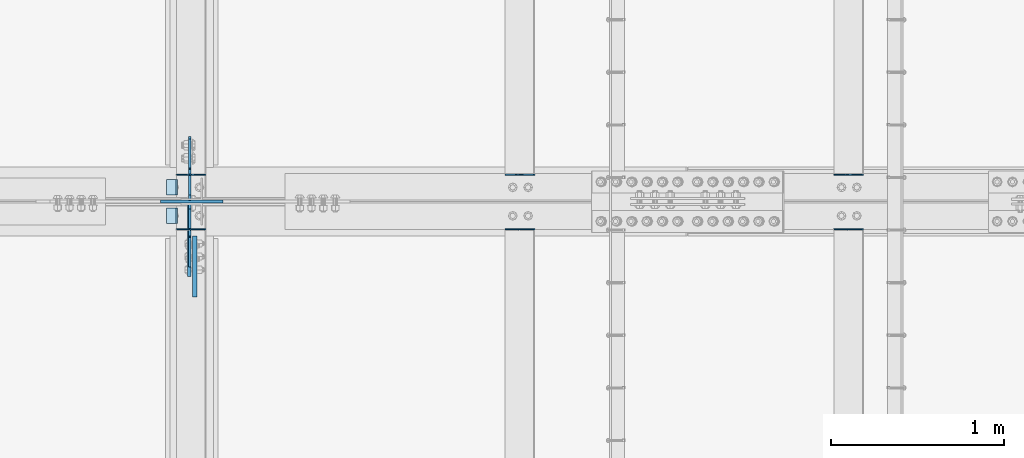
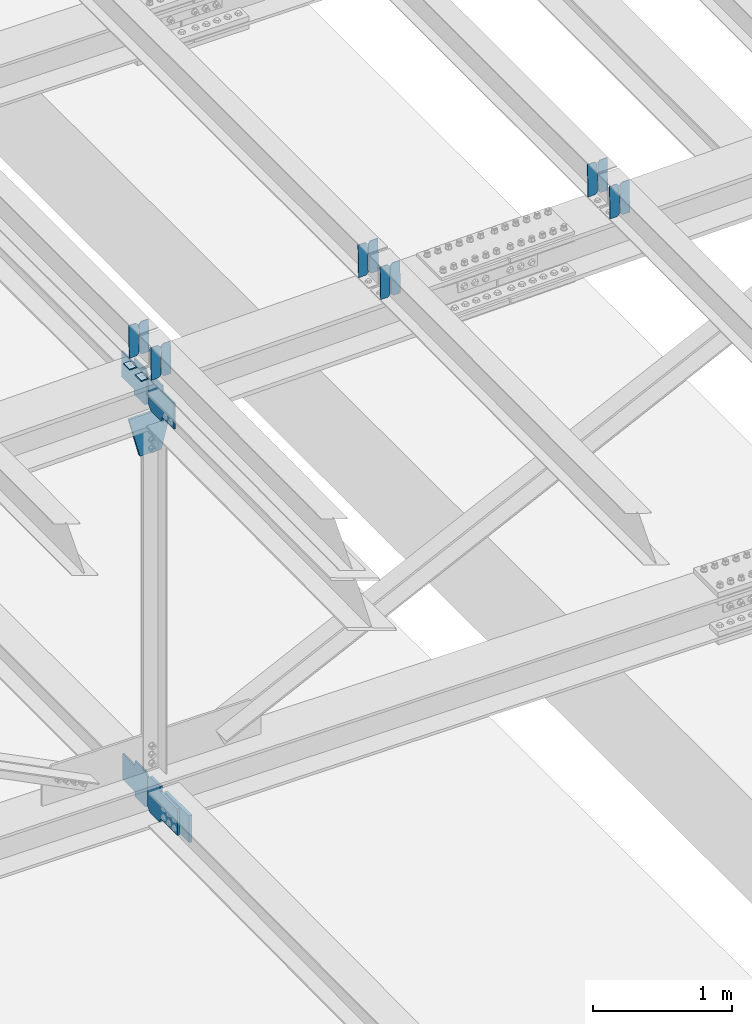
# One storey, part 3300 of 3843: 20 plates, 9 elements without a shape of their own.
"""IFC2X3 building model written with IfcOpenShell, lengths in millimetres."""

from ifc_helpers import new_model, si_unit, frame, origin_with_axes, place, context, subcontext, project, spatial, faceted_brep, material, type_object, element, aggregate, save


model = new_model("IFC2X3")

# Units and contexts
model_context = context("Model", 3, precision=1e-05, world=origin_with_axes())
body_context = subcontext(model_context, "Body", "Model", "MODEL_VIEW")
ifc_project = project(units=[si_unit("LENGTHUNIT", "METRE", prefix="MILLI"), si_unit("AREAUNIT", "SQUARE_METRE"), si_unit("VOLUMEUNIT", "CUBIC_METRE"), si_unit("MASSUNIT", "GRAM", prefix="KILO"), si_unit("TIMEUNIT", "SECOND"), si_unit("PLANEANGLEUNIT", "RADIAN"), si_unit("SOLIDANGLEUNIT", "STERADIAN"), si_unit("THERMODYNAMICTEMPERATUREUNIT", "DEGREE_CELSIUS"), si_unit("LUMINOUSINTENSITYUNIT", "LUMEN")], contexts=[model_context])

# Site, building, storey
site_placement = place(None, origin_with_axes())
site = spatial("IfcSite", under=ifc_project, at=site_placement, CompositionType="ELEMENT")
building_placement = place(site_placement, origin_with_axes())
building = spatial("IfcBuilding", under=site, at=building_placement, Name="Undefined", CompositionType="ELEMENT")
storey_placement = place(building_placement, origin_with_axes())
storey = spatial("IfcBuildingStorey", under=building, at=storey_placement, Name="Undefined", CompositionType="ELEMENT", Elevation=0.0)

# Assembly, plates
assembly_1_placement = place(storey_placement, origin_with_axes())
assembly_1 = element("IfcElementAssembly", 1, at=assembly_1_placement, inside=storey, Name="BEAM", AssemblyPlace="NOTDEFINED", PredefinedType="RIGID_FRAME")
ifc_material = material(Name="STEEL/A572-50")
plate_type_1 = type_object("IfcPlateType", PredefinedType="NOTDEFINED")
plate_1_placement = place(assembly_1_placement, frame((62718.6964784431, 42358.2339364471, 46061.7205786857), z_axis=(-0.0211520982314614, -0.0018756519998351, 0.999774509912101), x_axis=(-0.999776269352655, 3.88860000353947e-05, -0.0211520620074247)))
plate_1 = element("IfcPlate", 2, at=plate_1_placement, type_object=plate_type_1, material=ifc_material, Name="PLATE", context=body_context, shape_type="Brep", body=[
    faceted_brep([(0.0, -3.17499999999927, 0.0), (6.83940015733242e-10, -3.17499999996653, 288.924999998613), (6.54836185276508e-10, 3.17500000001746, 288.924999998591), (0.0, 3.17499999999927, 0.0), (60.3250007643655, -3.17500000017753, 288.924999998606), (60.3250007643219, 3.17499999979918, 288.924999998584), (79.3750000013097, -3.17500000025029, 269.875000761494), (79.375000001266, 3.17499999972642, 269.875000761487), (79.375000000713, -3.17500000026484, 19.0499992370605), (79.3750000006985, 3.17499999971187, 19.0499992370533), (60.325000763667, -3.17500000020664, -1.45519152283669e-11), (60.3250007636234, 3.17499999977736, -3.63797880709171e-11)], [[[0, 1, 2, 3]], [[1, 4, 5, 2]], [[4, 6, 7, 5]], [[6, 8, 9, 7]], [[8, 10, 11, 9]], [[10, 0, 3, 11]], [[5, 7, 9, 11, 3, 2]], [[10, 8, 6, 4, 1, 0]]]),
])
plate_2_placement = place(assembly_1_placement, frame((62632.9906577534, 42358.2373382604, 46059.9073182755), z_axis=(-0.0211520982314614, -0.0018756519998351, 0.999774509912101), x_axis=(-0.999776269352655, 3.88860000353947e-05, -0.0211520620074247)))
plate_2 = element("IfcPlate", 3, at=plate_2_placement, type_object=plate_type_1, material=ifc_material, Name="PLATE", context=body_context, shape_type="Brep", body=[
    faceted_brep([(4.36557456851006e-11, -3.17499999998836, 19.0499992370969), (6.11180439591408e-10, -3.17499999996653, 269.875000761516), (5.96628524363041e-10, 3.17500000001746, 269.875000761502), (1.45519152283669e-11, 3.17499999998836, 19.0499992370824), (19.0499992376572, -3.17500000003201, 288.924999998606), (19.0499992376281, 3.1749999999447, 288.924999998584), (79.3750000013242, -3.17500000025029, 288.924999998591), (79.3750000013097, 3.1749999997337, 288.92499999857), (79.3750000006548, -3.17500000026484, -2.18278728425503e-11), (79.3750000006403, 3.17499999969732, -2.91038304567337e-11), (19.0499992370023, -3.17500000005384, 0.0), (19.0499992369587, 3.17499999992287, -1.45519152283669e-11)], [[[0, 1, 2, 3]], [[1, 4, 5, 2]], [[4, 6, 7, 5]], [[6, 8, 9, 7]], [[8, 10, 11, 9]], [[10, 0, 3, 11]], [[5, 7, 9, 11, 3, 2]], [[10, 8, 6, 4, 1, 0]]]),
])

assembly_2_placement = place(storey_placement, origin_with_axes())
assembly_2 = element("IfcElementAssembly", 4, at=assembly_2_placement, inside=storey, Name="BEAM", AssemblyPlace="NOTDEFINED", PredefinedType="RIGID_FRAME")
plate_3_placement = place(assembly_2_placement, frame((62718.6964783463, 42042.5498323531, 46060.1628185439), z_axis=(-0.0211520980428759, -0.0079279149992217, 0.999744835901716), x_axis=(-0.99977626934649, 0.000167730000095165, -0.0211514330073057)))
plate_3 = element("IfcPlate", 5, at=plate_3_placement, type_object=plate_type_1, material=ifc_material, Name="PLATE", context=body_context, shape_type="Brep", body=[
    faceted_brep([(0.0, -3.17499999999927, 0.0), (6.83940015733242e-10, -3.17499999996653, 288.924999998613), (6.54836185276508e-10, 3.17500000001746, 288.924999998591), (0.0, 3.17499999999927, 0.0), (60.3250007643655, -3.17500000017753, 288.924999998606), (60.3250007643219, 3.17499999979918, 288.924999998584), (79.3750000013097, -3.17500000025029, 269.875000761494), (79.375000001266, 3.17499999972642, 269.875000761487), (79.375000000713, -3.17500000026484, 19.0499992370605), (79.3750000006985, 3.17499999971187, 19.0499992370533), (60.325000763667, -3.17500000020664, -1.45519152283669e-11), (60.3250007636234, 3.17499999977736, -3.63797880709171e-11)], [[[0, 1, 2, 3]], [[1, 4, 5, 2]], [[4, 6, 7, 5]], [[6, 8, 9, 7]], [[8, 10, 11, 9]], [[10, 0, 3, 11]], [[5, 7, 9, 11, 3, 2]], [[10, 8, 6, 4, 1, 0]]]),
])
plate_4_placement = place(assembly_2_placement, frame((62632.9906576567, 42042.5642109695, 46058.3496119529), z_axis=(-0.0211520980428759, -0.0079279149992217, 0.999744835901716), x_axis=(-0.99977626934649, 0.000167730000095165, -0.0211514330073057)))
plate_4 = element("IfcPlate", 6, at=plate_4_placement, type_object=plate_type_1, material=ifc_material, Name="PLATE", context=body_context, shape_type="Brep", body=[
    faceted_brep([(4.36557456851006e-11, -3.17499999998836, 19.0499992370969), (6.11180439591408e-10, -3.17499999996653, 269.875000761516), (5.96628524363041e-10, 3.17500000001746, 269.875000761502), (1.45519152283669e-11, 3.17499999998836, 19.0499992370824), (19.0499992376572, -3.17500000003201, 288.924999998606), (19.0499992376281, 3.1749999999447, 288.924999998584), (79.3750000013242, -3.17500000025029, 288.924999998591), (79.3750000013097, 3.1749999997337, 288.92499999857), (79.3750000006548, -3.17500000026484, -2.18278728425503e-11), (79.3750000006403, 3.17499999969732, -2.91038304567337e-11), (19.0499992370023, -3.17500000005384, 0.0), (19.0499992369587, 3.17499999992287, -1.45519152283669e-11)], [[[0, 1, 2, 3]], [[1, 4, 5, 2]], [[4, 6, 7, 5]], [[6, 8, 9, 7]], [[8, 10, 11, 9]], [[10, 0, 3, 11]], [[5, 7, 9, 11, 3, 2]], [[10, 8, 6, 4, 1, 0]]]),
])

assembly_3_placement = place(storey_placement, origin_with_axes())
assembly_3 = element("IfcElementAssembly", 7, at=assembly_3_placement, inside=storey, Name="BEAM", AssemblyPlace="NOTDEFINED", PredefinedType="RIGID_FRAME")
plate_5_placement = place(assembly_3_placement, frame((66528.6964782898, 42358.2722356688, 46144.1590912377), z_axis=(-0.0211520975136227, -0.00200431100054993, 0.999774260274882), x_axis=(-0.999776269341419, 4.27870000128944e-05, -0.0211520550071887)))
plate_5 = element("IfcPlate", 8, at=plate_5_placement, type_object=plate_type_1, material=ifc_material, Name="PLATE", context=body_context, shape_type="Brep", body=[
    faceted_brep([(0.0, -3.17499999999927, 0.0), (6.83940015733242e-10, -3.17499999996653, 288.924999998613), (6.54836185276508e-10, 3.17500000001746, 288.924999998591), (0.0, 3.17499999999927, 0.0), (60.3250007643655, -3.17500000017753, 288.924999998606), (60.3250007643219, 3.17499999979918, 288.924999998584), (79.3750000013097, -3.17500000025029, 269.875000761494), (79.375000001266, 3.17499999972642, 269.875000761487), (79.375000000713, -3.17500000026484, 19.0499992370605), (79.3750000006985, 3.17499999971187, 19.0499992370533), (60.325000763667, -3.17500000020664, -1.45519152283669e-11), (60.3250007636234, 3.17499999977736, -3.63797880709171e-11)], [[[0, 1, 2, 3]], [[1, 4, 5, 2]], [[4, 6, 7, 5]], [[6, 8, 9, 7]], [[8, 10, 11, 9]], [[10, 0, 3, 11]], [[5, 7, 9, 11, 3, 2]], [[10, 8, 6, 4, 1, 0]]]),
])
plate_6_placement = place(assembly_3_placement, frame((66442.9906575995, 42358.275870825, 46142.3458312798), z_axis=(-0.0211520975136227, -0.00200431100054993, 0.999774260274882), x_axis=(-0.999776269341419, 4.27870000128944e-05, -0.0211520550071887)))
plate_6 = element("IfcPlate", 9, at=plate_6_placement, type_object=plate_type_1, material=ifc_material, Name="PLATE", context=body_context, shape_type="Brep", body=[
    faceted_brep([(4.36557456851006e-11, -3.17499999998836, 19.0499992370969), (6.11180439591408e-10, -3.17499999996653, 269.875000761516), (5.96628524363041e-10, 3.17500000001746, 269.875000761502), (1.45519152283669e-11, 3.17499999998836, 19.0499992370824), (19.0499992376572, -3.17500000003201, 288.924999998606), (19.0499992376281, 3.1749999999447, 288.924999998584), (79.3750000013242, -3.17500000025029, 288.924999998591), (79.3750000013097, 3.1749999997337, 288.92499999857), (79.3750000006548, -3.17500000026484, -2.18278728425503e-11), (79.3750000006403, 3.17499999969732, -2.91038304567337e-11), (19.0499992370023, -3.17500000005384, 0.0), (19.0499992369587, 3.17499999992287, -1.45519152283669e-11)], [[[0, 1, 2, 3]], [[1, 4, 5, 2]], [[4, 6, 7, 5]], [[6, 8, 9, 7]], [[8, 10, 11, 9]], [[10, 0, 3, 11]], [[5, 7, 9, 11, 3, 2]], [[10, 8, 6, 4, 1, 0]]]),
])
aggregate(assembly_3, [plate_5, plate_6])

assembly_4_placement = place(storey_placement, origin_with_axes())
assembly_4 = element("IfcElementAssembly", 10, at=assembly_4_placement, inside=storey, Name="BEAM", AssemblyPlace="NOTDEFINED", PredefinedType="RIGID_FRAME")
plate_7_placement = place(assembly_4_placement, frame((66528.6964782749, 42042.5488447947, 46142.5816774789), z_axis=(-0.0211520974882006, -0.00792463099960153, 0.999744861949973), x_axis=(-0.99977626934649, 0.000167730000095165, -0.0211514330073057)))
plate_7 = element("IfcPlate", 11, at=plate_7_placement, type_object=plate_type_1, material=ifc_material, Name="PLATE", context=body_context, shape_type="Brep", body=[
    faceted_brep([(0.0, -3.17499999999927, 0.0), (6.83940015733242e-10, -3.17499999996653, 288.924999998613), (6.54836185276508e-10, 3.17500000001746, 288.924999998591), (0.0, 3.17499999999927, 0.0), (60.3250007643655, -3.17500000017753, 288.924999998606), (60.3250007643219, 3.17499999979918, 288.924999998584), (79.3750000013097, -3.17500000025029, 269.875000761494), (79.375000001266, 3.17499999972642, 269.875000761487), (79.375000000713, -3.17500000026484, 19.0499992370605), (79.3750000006985, 3.17499999971187, 19.0499992370533), (60.325000763667, -3.17500000020664, -1.45519152283669e-11), (60.3250007636234, 3.17499999977736, -3.63797880709171e-11)], [[[0, 1, 2, 3]], [[1, 4, 5, 2]], [[4, 6, 7, 5]], [[6, 8, 9, 7]], [[8, 10, 11, 9]], [[10, 0, 3, 11]], [[5, 7, 9, 11, 3, 2]], [[10, 8, 6, 4, 1, 0]]]),
])
plate_8_placement = place(assembly_4_placement, frame((66442.9906575837, 42042.5632174562, 46140.7684708411), z_axis=(-0.0211520974882006, -0.00792463099960153, 0.999744861949973), x_axis=(-0.99977626934649, 0.000167730000095165, -0.0211514330073057)))
plate_8 = element("IfcPlate", 12, at=plate_8_placement, type_object=plate_type_1, material=ifc_material, Name="PLATE", context=body_context, shape_type="Brep", body=[
    faceted_brep([(4.36557456851006e-11, -3.17499999998836, 19.0499992370969), (6.11180439591408e-10, -3.17499999996653, 269.875000761516), (5.96628524363041e-10, 3.17500000001746, 269.875000761502), (1.45519152283669e-11, 3.17499999998836, 19.0499992370824), (19.0499992376572, -3.17500000003201, 288.924999998606), (19.0499992376281, 3.1749999999447, 288.924999998584), (79.3750000013242, -3.17500000025029, 288.924999998591), (79.3750000013097, 3.1749999997337, 288.92499999857), (79.3750000006548, -3.17500000026484, -2.18278728425503e-11), (79.3750000006403, 3.17499999969732, -2.91038304567337e-11), (19.0499992370023, -3.17500000005384, 0.0), (19.0499992369587, 3.17499999992287, -1.45519152283669e-11)], [[[0, 1, 2, 3]], [[1, 4, 5, 2]], [[4, 6, 7, 5]], [[6, 8, 9, 7]], [[8, 10, 11, 9]], [[10, 0, 3, 11]], [[5, 7, 9, 11, 3, 2]], [[10, 8, 6, 4, 1, 0]]]),
])
aggregate(assembly_4, [plate_7, plate_8])

assembly_5_placement = place(storey_placement, origin_with_axes())
assembly_5 = element("IfcElementAssembly", 13, at=assembly_5_placement, inside=storey, Name="BEAM", AssemblyPlace="NOTDEFINED", PredefinedType="RIGID_FRAME")
plate_9_placement = place(assembly_5_placement, frame((64623.6964782845, 42358.2545172086, 46103.2604970956), z_axis=(-0.0211520980268542, -0.00194478699965839, 0.999774377823611), x_axis=(-0.999776269338345, 4.08370000139469e-05, -0.0211520590071252)))
plate_9 = element("IfcPlate", 14, at=plate_9_placement, type_object=plate_type_1, material=ifc_material, Name="PLATE", context=body_context, shape_type="Brep", body=[
    faceted_brep([(0.0, -3.17499999999927, 0.0), (6.83940015733242e-10, -3.17499999996653, 288.924999998613), (6.54836185276508e-10, 3.17500000001746, 288.924999998591), (0.0, 3.17499999999927, 0.0), (60.3250007643655, -3.17500000017753, 288.924999998606), (60.3250007643219, 3.17499999979918, 288.924999998584), (79.3750000013097, -3.17500000025029, 269.875000761494), (79.375000001266, 3.17499999972642, 269.875000761487), (79.375000000713, -3.17500000026484, 19.0499992370605), (79.3750000006985, 3.17499999971187, 19.0499992370533), (60.325000763667, -3.17500000020664, -1.45519152283669e-11), (60.3250007636234, 3.17499999977736, -3.63797880709171e-11)], [[[0, 1, 2, 3]], [[1, 4, 5, 2]], [[4, 6, 7, 5]], [[6, 8, 9, 7]], [[8, 10, 11, 9]], [[10, 0, 3, 11]], [[5, 7, 9, 11, 3, 2]], [[10, 8, 6, 4, 1, 0]]]),
])
plate_10_placement = place(assembly_5_placement, frame((64537.9906575949, 42358.2580444088, 46101.4472369255), z_axis=(-0.0211520980268542, -0.00194478699965839, 0.999774377823611), x_axis=(-0.999776269338345, 4.08370000139469e-05, -0.0211520590071252)))
plate_10 = element("IfcPlate", 15, at=plate_10_placement, type_object=plate_type_1, material=ifc_material, Name="PLATE", context=body_context, shape_type="Brep", body=[
    faceted_brep([(4.36557456851006e-11, -3.17499999998836, 19.0499992370969), (6.11180439591408e-10, -3.17499999996653, 269.875000761516), (5.96628524363041e-10, 3.17500000001746, 269.875000761502), (1.45519152283669e-11, 3.17499999998836, 19.0499992370824), (19.0499992376572, -3.17500000003201, 288.924999998606), (19.0499992376281, 3.1749999999447, 288.924999998584), (79.3750000013242, -3.17500000025029, 288.924999998591), (79.3750000013097, 3.1749999997337, 288.92499999857), (79.3750000006548, -3.17500000026484, -2.18278728425503e-11), (79.3750000006403, 3.17499999969732, -2.91038304567337e-11), (19.0499992370023, -3.17500000005384, 0.0), (19.0499992369587, 3.17499999992287, -1.45519152283669e-11)], [[[0, 1, 2, 3]], [[1, 4, 5, 2]], [[4, 6, 7, 5]], [[6, 8, 9, 7]], [[8, 10, 11, 9]], [[10, 0, 3, 11]], [[5, 7, 9, 11, 3, 2]], [[10, 8, 6, 4, 1, 0]]]),
])
aggregate(assembly_5, [plate_9, plate_10])

assembly_6_placement = place(storey_placement, origin_with_axes())
assembly_6 = element("IfcElementAssembly", 16, at=assembly_6_placement, inside=storey, Name="BEAM", AssemblyPlace="NOTDEFINED", PredefinedType="RIGID_FRAME")
plate_11_placement = place(assembly_6_placement, frame((64623.6964782752, 42042.5608506591, 46101.6861400018), z_axis=(-0.0211520981947687, -0.0079645429981683, 0.999744544769707), x_axis=(-0.99977626934649, 0.000167730000095165, -0.0211514330073057)))
plate_11 = element("IfcPlate", 17, at=plate_11_placement, type_object=plate_type_1, material=ifc_material, Name="PLATE", context=body_context, shape_type="Brep", body=[
    faceted_brep([(0.0, -3.17499999999927, 0.0), (6.83940015733242e-10, -3.17499999996653, 288.924999998613), (6.54836185276508e-10, 3.17500000001746, 288.924999998591), (0.0, 3.17499999999927, 0.0), (60.3250007643655, -3.17500000017753, 288.924999998606), (60.3250007643219, 3.17499999979918, 288.924999998584), (79.3750000013097, -3.17500000025029, 269.875000761494), (79.375000001266, 3.17499999972642, 269.875000761487), (79.375000000713, -3.17500000026484, 19.0499992370605), (79.3750000006985, 3.17499999971187, 19.0499992370533), (60.325000763667, -3.17500000020664, -1.45519152283669e-11), (60.3250007636234, 3.17499999977736, -3.63797880709171e-11)], [[[0, 1, 2, 3]], [[1, 4, 5, 2]], [[4, 6, 7, 5]], [[6, 8, 9, 7]], [[8, 10, 11, 9]], [[10, 0, 3, 11]], [[5, 7, 9, 11, 3, 2]], [[10, 8, 6, 4, 1, 0]]]),
])
plate_12_placement = place(assembly_6_placement, frame((64537.9906575859, 42042.5752957059, 46099.8729339395), z_axis=(-0.0211520981947687, -0.0079645429981683, 0.999744544769707), x_axis=(-0.99977626934649, 0.000167730000095165, -0.0211514330073057)))
plate_12 = element("IfcPlate", 18, at=plate_12_placement, type_object=plate_type_1, material=ifc_material, Name="PLATE", context=body_context, shape_type="Brep", body=[
    faceted_brep([(4.36557456851006e-11, -3.17499999998836, 19.0499992370969), (6.11180439591408e-10, -3.17499999996653, 269.875000761516), (5.96628524363041e-10, 3.17500000001746, 269.875000761502), (1.45519152283669e-11, 3.17499999998836, 19.0499992370824), (19.0499992376572, -3.17500000003201, 288.924999998606), (19.0499992376281, 3.1749999999447, 288.924999998584), (79.3750000013242, -3.17500000025029, 288.924999998591), (79.3750000013097, 3.1749999997337, 288.92499999857), (79.3750000006548, -3.17500000026484, -2.18278728425503e-11), (79.3750000006403, 3.17499999969732, -2.91038304567337e-11), (19.0499992370023, -3.17500000005384, 0.0), (19.0499992369587, 3.17499999992287, -1.45519152283669e-11)], [[[0, 1, 2, 3]], [[1, 4, 5, 2]], [[4, 6, 7, 5]], [[6, 8, 9, 7]], [[8, 10, 11, 9]], [[10, 0, 3, 11]], [[5, 7, 9, 11, 3, 2]], [[10, 8, 6, 4, 1, 0]]]),
])
aggregate(assembly_6, [plate_11, plate_12])

# Plate
plate_type_2 = type_object("IfcPlateType", PredefinedType="NOTDEFINED")
plate_13_placement = place(assembly_1_placement, frame((62553.7677265444, 42329.1, 46051.5871230104), z_axis=(0.0, -1.0, 0.0), x_axis=(-0.999776270257024, 0.0, -0.0211520550054595)))
plate_13 = element("IfcPlate", 19, at=plate_13_placement, type_object=plate_type_2, material=ifc_material, Name="PLATE", context=body_context, shape_type="Brep", body=[
    faceted_brep([(9.52499999982683, -4.7625000001135, 88.8999999999942), (0.0, 4.76249999999709, 88.9000015258789), (0.0, 4.76249999999709, 0.0), (9.52499999981956, -4.76249999999709, 0.0), (63.4999984608512, -4.76249999988795, 88.8999999999796), (63.4999984608367, -4.76249999988795, -1.45519152283669e-11), (63.4999984608221, 4.76250000013533, -1.45519152283669e-11), (63.4999984608367, 4.76250000013533, 88.8999999999796)], [[[0, 1, 2, 3]], [[4, 5, 6, 7]], [[5, 4, 0, 3]], [[6, 5, 3, 2]], [[7, 6, 2, 1]], [[4, 7, 1, 0]]]),
])

aggregate(assembly_1, [plate_1, plate_2, plate_13])

plate_14_placement = place(assembly_2_placement, frame((62553.7677265444, 42164.0000015258, 46051.5871230104), z_axis=(0.0, -1.0, 0.0), x_axis=(-0.999776270257024, 0.0, -0.0211520550054595)))
plate_14 = element("IfcPlate", 20, at=plate_14_placement, type_object=plate_type_2, material=ifc_material, Name="PLATE", context=body_context, shape_type="Brep", body=[
    faceted_brep([(9.52499999982683, -4.7625000001135, 88.8999999999942), (0.0, 4.76249999999709, 88.9000015258789), (0.0, 4.76249999999709, 0.0), (9.52499999981956, -4.76249999999709, 0.0), (63.4999984608512, -4.76249999988795, 88.8999999999796), (63.4999984608367, -4.76249999988795, -1.45519152283669e-11), (63.4999984608221, 4.76250000013533, -1.45519152283669e-11), (63.4999984608367, 4.76250000013533, 88.8999999999796)], [[[0, 1, 2, 3]], [[4, 5, 6, 7]], [[5, 4, 0, 3]], [[6, 5, 3, 2]], [[7, 6, 2, 1]], [[4, 7, 1, 0]]]),
])

aggregate(assembly_2, [plate_3, plate_4, plate_14])

# Assembly, plate
assembly_7_placement = place(storey_placement, origin_with_axes())
assembly_7 = element("IfcElementAssembly", 21, at=assembly_7_placement, inside=storey, Name="BEAM", AssemblyPlace="NOTDEFINED", PredefinedType="RIGID_FRAME")
plate_type_3 = type_object("IfcPlateType", PredefinedType="NOTDEFINED")
plate_15_placement = place(assembly_7_placement, frame((62625.2874998521, 42209.24375, 42198.3712367481), z_axis=(0.0, 0.707106781186548, 0.707106781186548), x_axis=(5.70000238222118e-08, 0.707106781186546, -0.707106781186546)))
plate_15 = element("IfcPlate", 22, at=plate_15_placement, type_object=plate_type_3, material=ifc_material, Name="PLATE", context=body_context, shape_type="Brep", body=[
    faceted_brep([(0.0, -6.3499999046162, 0.0), (-179.597849441064, -6.34999999999854, 179.597849441059), (-179.597849441064, 6.34999999999854, 179.597849441059), (7.27595761418343e-12, 6.3499999046162, 0.0), (-179.597849441061, -6.34999999999854, 224.499130046192), (-179.597849441061, 6.34999999999854, 224.499130046192), (-75.7636380416931, -6.34999999999854, 328.333341445563), (-75.7636380416931, 6.34999999999854, 328.333341445563), (-53.6130214959755, -6.34999999999854, 306.182724899838), (-53.6130214959755, 6.34999999999854, 306.182724899838), (-49.4928450278291, -6.34999999999854, 303.429710999371), (-49.4928450278291, 6.34999999999854, 303.429710999371), (-44.6327655097972, -6.34999999999854, 302.462981076787), (-44.6327655097972, 6.34999999999854, 302.462981076787), (-39.7726859917617, -6.34999999999854, 303.429710999371), (-39.7726859917617, 6.34999999999854, 303.429710999371), (-35.652509523619, -6.34999999999854, 306.182724899838), (-35.652509523619, 6.34999999999854, 306.182724899838), (81.0908201845581, -6.34999999999854, 422.926054608019), (81.0908201845581, 6.34999999999854, 422.926054608019), (242.735430363026, -6.34999999999854, 261.281444429551), (242.735430363026, 6.34999999999854, 261.281444429551), (125.992100654849, -6.34999999999854, 144.53811472137), (125.992100654849, 6.34999999999854, 144.53811472137), (123.239086754382, -6.34999999999854, 140.417938253224), (123.239086754382, 6.34999999999854, 140.417938253224), (122.272356831791, -6.34999999999854, 135.557858735199), (122.272356831791, 6.34999999999854, 135.557858735199), (123.239086754382, -6.34999999999854, 130.69777921716), (123.239086754382, 6.34999999999854, 130.69777921716), (125.992100654849, -6.34999999999854, 126.577602749014), (125.992100654849, 6.34999999999854, 126.577602749014), (148.735492004496, -6.35000000000582, 103.834211399357), (148.735492004496, 6.35000000000582, 103.834211399357), (44.9012806051323, -6.35000000000582, -1.45519152283669e-11), (44.9012806051323, 6.35000000000582, -1.45519152283669e-11)], [[[0, 1, 2, 3]], [[1, 4, 5, 2]], [[4, 6, 7, 5]], [[6, 8, 9, 7]], [[8, 10, 11, 9]], [[10, 12, 13, 11]], [[12, 14, 15, 13]], [[14, 16, 17, 15]], [[16, 18, 19, 17]], [[18, 20, 21, 19]], [[20, 22, 23, 21]], [[22, 24, 25, 23]], [[24, 26, 27, 25]], [[26, 28, 29, 27]], [[28, 30, 31, 29]], [[30, 32, 33, 31]], [[32, 34, 35, 33]], [[34, 0, 3, 35]], [[5, 7, 9, 11, 13, 15, 17, 19, 21, 23, 25, 27, 29, 31, 33, 35, 3, 2]], [[34, 32, 30, 28, 26, 24, 22, 20, 18, 16, 14, 12, 10, 8, 6, 4, 1, 0]]]),
])

# Assembly, plates
assembly_8_placement = place(storey_placement, origin_with_axes())
assembly_8 = element("IfcElementAssembly", 23, at=assembly_8_placement, inside=storey, Name="BEAM", AssemblyPlace="NOTDEFINED", PredefinedType="RIGID_FRAME")
plate_16_placement = place(assembly_8_placement, frame((62625.2874998909, 42213.2125, 45724.5288118974), z_axis=(0.0, 0.707106781186548, 0.707106781186548), x_axis=(5.70000238222118e-08, 0.707106781186546, -0.707106781186546)))
plate_16 = element("IfcPlate", 24, at=plate_16_placement, type_object=plate_type_3, material=ifc_material, Name="PLATE", context=body_context, shape_type="Brep", body=[
    faceted_brep([(0.0, -6.3499999046162, 0.0), (-179.463032808948, -6.34999999999854, 179.463032808635), (-179.463032808948, 6.34999999999854, 179.463032808635), (7.27595761418343e-12, 6.3499999046162, 0.0), (-179.463032808992, -6.34999999999854, 224.364313413753), (-179.463032808992, 6.34999999999854, 224.364313413753), (-68.332363235801, -6.34999999999854, 335.494982985998), (-68.332363235801, 6.34999999999854, 335.494982985998), (-46.4665045499755, -6.34999999999854, 313.629124300205), (-46.4665045499755, 6.34999999999854, 313.629124300205), (-42.3463280818473, -6.34999999999854, 310.876110399739), (-42.3463280818473, 6.34999999999854, 310.876110399739), (-37.48624856383, -6.34999999999854, 309.909380477155), (-37.48624856383, 6.34999999999854, 309.909380477155), (-32.6261690458091, -6.34999999999854, 310.876110399731), (-32.6261690458091, 6.34999999999854, 310.876110399731), (-28.5059925776736, -6.34999999999854, 313.629124300176), (-28.5059925776736, 6.34999999999854, 313.629124300176), (88.2373370560413, -6.34999999999854, 430.372453932898), (88.2373370560413, 6.34999999999854, 430.372453932898), (249.88194723548, -6.34999999999854, 268.727843753732), (249.88194723548, 6.34999999999854, 268.727843753732), (133.138617601856, -6.34999999999854, 151.984514121097), (133.138617601856, 6.34999999999854, 151.984514121097), (130.385603701357, -6.34999999999854, 147.864337652951), (130.385603701357, 6.34999999999854, 147.864337652951), (129.418873778762, -6.34999999999854, 143.004258134912), (129.418873778762, 6.34999999999854, 143.004258134912), (130.385603701342, -6.34999999999854, 138.144178616851), (130.385603701342, 6.34999999999854, 138.144178616851), (133.138617601831, -6.34999999999854, 134.024002148697), (133.138617601831, 6.34999999999854, 134.024002148697), (156.031950102829, -6.35000000000582, 111.130669497703), (156.031950102829, 6.35000000000582, 111.130669497703), (44.9012806051323, -6.35000000000582, -1.45519152283669e-11), (44.9012806051323, 6.35000000000582, -1.45519152283669e-11)], [[[0, 1, 2, 3]], [[1, 4, 5, 2]], [[4, 6, 7, 5]], [[6, 8, 9, 7]], [[8, 10, 11, 9]], [[10, 12, 13, 11]], [[12, 14, 15, 13]], [[14, 16, 17, 15]], [[16, 18, 19, 17]], [[18, 20, 21, 19]], [[20, 22, 23, 21]], [[22, 24, 25, 23]], [[24, 26, 27, 25]], [[26, 28, 29, 27]], [[28, 30, 31, 29]], [[30, 32, 33, 31]], [[32, 34, 35, 33]], [[34, 0, 3, 35]], [[5, 7, 9, 11, 13, 15, 17, 19, 21, 23, 25, 27, 29, 31, 33, 35, 3, 2]], [[34, 32, 30, 28, 26, 24, 22, 20, 18, 16, 14, 12, 10, 8, 6, 4, 1, 0]]]),
])
plate_17_placement = place(assembly_8_placement, frame((62625.2875706698, 42190.9874999759, 45724.5288134694), z_axis=(0.0, -0.707106781186682, 0.707106781186413), x_axis=(0.0, -0.707106781186548, -0.707106781186548)))
plate_17 = element("IfcPlate", 25, at=plate_17_placement, type_object=plate_type_3, material=ifc_material, Name="PLATE", context=body_context, shape_type="Brep", body=[
    faceted_brep([(0.0, -6.3499999046162, 0.0), (-179.463032808948, -6.34999999999854, 179.463032808635), (-179.463032808948, 6.34999999999854, 179.463032808635), (7.27595761418343e-12, 6.3499999046162, 0.0), (-179.463032808992, -6.34999999999854, 224.364313413753), (-179.463032808992, 6.34999999999854, 224.364313413753), (-68.332363235801, -6.34999999999854, 335.494982985998), (-68.332363235801, 6.34999999999854, 335.494982985998), (-44.6841798851528, -6.34999999999854, 311.846799503114), (-44.6841798851528, 6.34999999999854, 311.846799503114), (-40.564003417021, -6.34999999999854, 309.09378560264), (-40.564003417021, 6.34999999999854, 309.09378560264), (-35.7039238989819, -6.34999999999854, 308.127055680056), (-35.7039238989819, 6.34999999999854, 308.127055680056), (-30.8438443809428, -6.34999999999854, 309.093785602647), (-30.8438443809428, 6.34999999999854, 309.093785602647), (-26.7236679127964, -6.34999999999854, 311.846799503114), (-26.7236679127964, 6.34999999999854, 311.846799503114), (90.0196617893234, -6.34999999999854, 428.590129205244), (90.0196617893234, 6.34999999999854, 428.590129205244), (251.664271967791, -6.34999999999854, 266.945519026769), (251.664271967791, 6.34999999999854, 266.945519026769), (134.920942265657, -6.34999999999854, 150.202189324639), (134.920942265657, 6.34999999999854, 150.202189324639), (132.167928365197, -6.34999999999854, 146.082012856496), (132.167928365197, 6.34999999999854, 146.082012856496), (131.201198442606, -6.34999999999854, 141.221933338468), (131.201198442606, 6.34999999999854, 141.221933338468), (132.16792836519, -6.34999999999854, 136.361853820429), (132.16792836519, 6.34999999999854, 136.361853820429), (134.920942265671, -6.34999999999854, 132.24167735229), (134.920942265671, 6.34999999999854, 132.24167735229), (156.031950102829, -6.35000000000582, 111.130669497703), (156.031950102829, 6.35000000000582, 111.130669497703), (44.9012806051323, -6.35000000000582, -1.45519152283669e-11), (44.9012806051323, 6.35000000000582, -1.45519152283669e-11)], [[[0, 1, 2, 3]], [[1, 4, 5, 2]], [[4, 6, 7, 5]], [[6, 8, 9, 7]], [[8, 10, 11, 9]], [[10, 12, 13, 11]], [[12, 14, 15, 13]], [[14, 16, 17, 15]], [[16, 18, 19, 17]], [[18, 20, 21, 19]], [[20, 22, 23, 21]], [[22, 24, 25, 23]], [[24, 26, 27, 25]], [[26, 28, 29, 27]], [[28, 30, 31, 29]], [[30, 32, 33, 31]], [[32, 34, 35, 33]], [[34, 0, 3, 35]], [[5, 7, 9, 11, 13, 15, 17, 19, 21, 23, 25, 27, 29, 31, 33, 35, 3, 2]], [[34, 32, 30, 28, 26, 24, 22, 20, 18, 16, 14, 12, 10, 8, 6, 4, 1, 0]]]),
])

# Plate
plate_type_4 = type_object("IfcPlateType", PredefinedType="NOTDEFINED")
plate_18_placement = place(assembly_7_placement, frame((62622.1125623855, 42194.9562499539, 42198.371097828), z_axis=(0.0, -0.707106781186682, 0.707106781186413), x_axis=(0.0, -0.707106781186548, -0.707106781186548)))
plate_18 = element("IfcPlate", 26, at=plate_18_placement, type_object=plate_type_4, material=ifc_material, Name="PLATE", context=body_context, shape_type="Brep", body=[
    faceted_brep([(0.0, -9.52500000000146, 0.0), (-179.594171692268, -9.52500000000146, 179.594171692269), (-179.594171692268, 9.52500000000146, 179.594171692269), (0.0, 9.52500000000146, 0.0), (-179.594171692268, -9.52500000000146, 224.495452297391), (-179.594171692268, 9.52500000000146, 224.495452297391), (-75.7599603253911, -9.52500000000146, 328.329663664257), (-75.7599603253911, 9.52500000000146, 328.329663664257), (-51.9620590348495, -9.52500000000146, 304.531762373708), (-51.9620590348495, 9.52500000000146, 304.531762373708), (-47.8418825667031, -9.52500000000146, 301.778748473234), (-47.8418825667031, 9.52500000000146, 301.778748473234), (-42.9818030486786, -9.52500000000146, 300.812018550643), (-42.9818030486786, 9.52500000000146, 300.812018550643), (-38.1217235306394, -9.52500000000146, 301.778748473227), (-38.1217235306394, 9.52500000000146, 301.778748473227), (-34.001547062493, -9.52500000000146, 304.531762373697), (-34.001547062493, 9.52500000000146, 304.531762373697), (132.133191343833, -9.52500000000146, 470.666500780027), (132.133191343833, 9.52500000000146, 470.666500780027), (298.267929582813, -9.52500000000146, 304.531762541048), (298.267929582813, 9.52500000000146, 304.531762541048), (132.133191176501, -9.52500000000146, 138.397024134721), (132.133191176501, 9.52500000000146, 138.397024134721), (129.380177276027, -9.52500000000146, 134.276847666578), (129.380177276027, 9.52500000000146, 134.276847666578), (128.413447353436, -9.52500000000146, 129.416768148547), (128.413447353436, 9.52500000000146, 129.416768148547), (129.38017727602, -9.52500000000146, 124.556688630507), (129.38017727602, 9.52500000000146, 124.556688630507), (132.133191176494, -9.52500000000146, 120.436512162368), (132.133191176494, 9.52500000000146, 120.436512162368), (148.735492003645, -9.52499999999418, 103.834211398527), (148.735492003645, 9.52499999999418, 103.834211398527), (44.9012806055835, -9.52499999999418, 4.65661287307739e-10), (44.9012806055835, 9.52499999999418, 4.65661287307739e-10)], [[[0, 1, 2, 3]], [[1, 4, 5, 2]], [[4, 6, 7, 5]], [[6, 8, 9, 7]], [[8, 10, 11, 9]], [[10, 12, 13, 11]], [[12, 14, 15, 13]], [[14, 16, 17, 15]], [[16, 18, 19, 17]], [[18, 20, 21, 19]], [[20, 22, 23, 21]], [[22, 24, 25, 23]], [[24, 26, 27, 25]], [[26, 28, 29, 27]], [[28, 30, 31, 29]], [[30, 32, 33, 31]], [[32, 34, 35, 33]], [[34, 0, 3, 35]], [[5, 7, 9, 11, 13, 15, 17, 19, 21, 23, 25, 27, 29, 31, 33, 35, 3, 2]], [[34, 32, 30, 28, 26, 24, 22, 20, 18, 16, 14, 12, 10, 8, 6, 4, 1, 0]]]),
])

aggregate(assembly_7, [plate_15, plate_18])

# Assembly, plate
assembly_9_placement = place(storey_placement, origin_with_axes())
assembly_9 = element("IfcElementAssembly", 27, at=assembly_9_placement, inside=storey, Name="BEAM", AssemblyPlace="NOTDEFINED", PredefinedType="RIGID_FRAME")
plate_type_5 = type_object("IfcPlateType", PredefinedType="NOTDEFINED")
plate_19_placement = place(assembly_9_placement, frame((62653.8625000005, 41648.0625002344, 42437.7502964492), z_axis=(0.0, 0.0, -1.0), x_axis=(0.0, 1.0, 0.0)))
plate_19 = element("IfcPlate", 28, at=plate_19_placement, type_object=plate_type_5, material=ifc_material, Name="PLATE", context=body_context, shape_type="Brep", body=[
    faceted_brep([(0.0, -12.6999999999971, 0.0), (1.45519152283669e-11, -12.6999999999971, 234.949999999342), (1.45519152283669e-11, 12.6999999999971, 234.949999999342), (0.0, 12.6999999999971, 0.0), (355.60000000002, -12.6999999999971, 234.949999999342), (355.60000000002, 12.6999999999971, 234.949999999342), (355.599999999999, -12.7000000000007, 0.0), (355.599999999999, 12.7000000000007, 0.0)], [[[0, 1, 2, 3]], [[1, 4, 5, 2]], [[4, 6, 7, 5]], [[6, 0, 3, 7]], [[5, 7, 3, 2]], [[6, 4, 1, 0]]]),
])
aggregate(assembly_9, [plate_19])

# Plate
plate_type_6 = type_object("IfcPlateType", PredefinedType="NOTDEFINED")
plate_20_placement = place(assembly_8_placement, frame((62818.8288507414, 42202.1, 45658.7890754668), z_axis=(0.0219709250020387, 0.0, -0.999758610092734), x_axis=(-0.999758610092734, 0.0, -0.0219709250020408)))
plate_20 = element("IfcPlate", 29, at=plate_20_placement, type_object=plate_type_6, material=ifc_material, Name="PLATE", context=body_context, shape_type="Brep", body=[
    faceted_brep([(0.0, -9.52500000000146, 0.0), (101.420568807996, -9.52500000000146, 358.074962194522), (101.420568807996, 9.52500000000146, 358.074962194522), (0.0, 9.52500000000146, 0.0), (279.177650582955, -9.52500000000146, 354.168531570082), (279.177650582955, 9.52500000000146, 354.168531570082), (363.260265879144, -9.52500000000146, -2.61934474110603e-10), (363.260265879144, 9.52500000000146, -2.61934474110603e-10)], [[[0, 1, 2, 3]], [[1, 4, 5, 2]], [[4, 6, 7, 5]], [[6, 0, 3, 7]], [[5, 7, 3, 2]], [[6, 4, 1, 0]]]),
])

aggregate(assembly_8, [plate_16, plate_17, plate_20])

save(model, "model.ifc")
